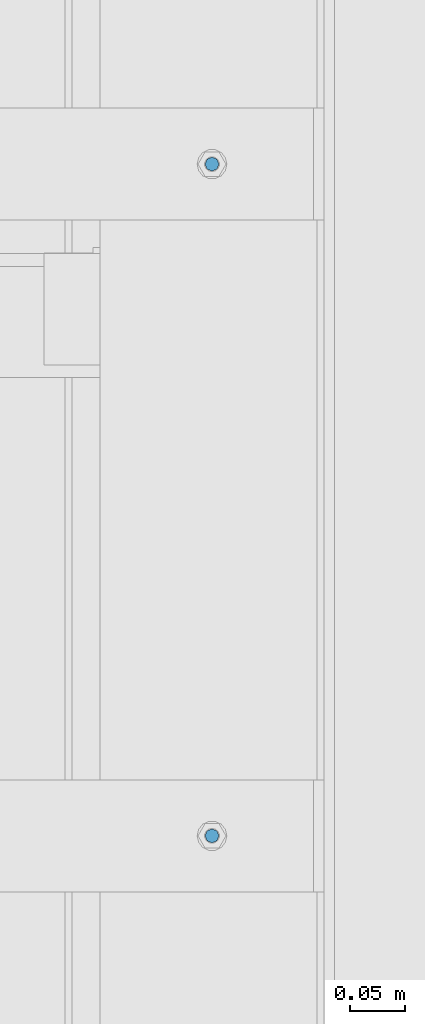
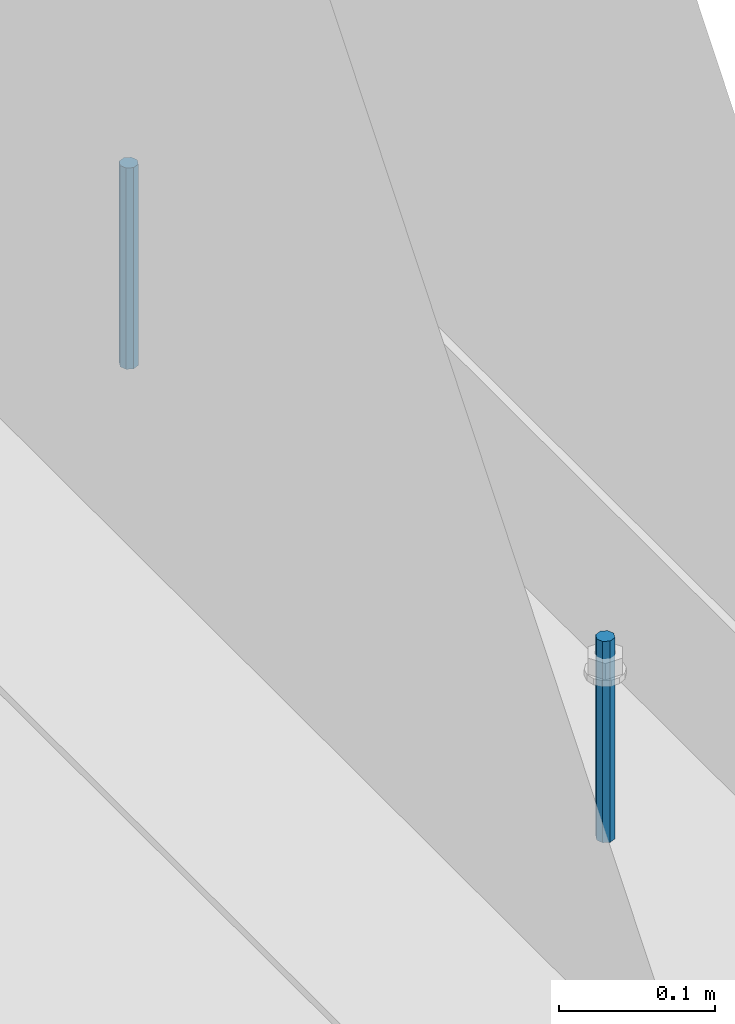
# One storey, part 447 of 1179: 2 columns, 1 element without a shape of its own.
"""IFC2X3 building model written with IfcOpenShell, lengths in millimetres."""

from ifc_helpers import new_model, si_unit, frame, origin_with_axes, place, context, subcontext, project, spatial, faceted_brep, material, type_object, element, aggregate, save


model = new_model("IFC2X3")

# Units and contexts
model_context = context("Model", 3, precision=1e-05, world=origin_with_axes())
body_context = subcontext(model_context, "Body", "Model", "MODEL_VIEW")
ifc_project = project(units=[si_unit("LENGTHUNIT", "METRE", prefix="MILLI"), si_unit("AREAUNIT", "SQUARE_METRE"), si_unit("VOLUMEUNIT", "CUBIC_METRE"), si_unit("MASSUNIT", "GRAM", prefix="KILO"), si_unit("TIMEUNIT", "SECOND"), si_unit("PLANEANGLEUNIT", "RADIAN"), si_unit("SOLIDANGLEUNIT", "STERADIAN"), si_unit("THERMODYNAMICTEMPERATUREUNIT", "DEGREE_CELSIUS"), si_unit("LUMINOUSINTENSITYUNIT", "LUMEN")], contexts=[model_context])

# Site, building, storey
site_placement = place(None, origin_with_axes())
site = spatial("IfcSite", under=ifc_project, at=site_placement, CompositionType="ELEMENT")
building_placement = place(site_placement, origin_with_axes())
building = spatial("IfcBuilding", under=site, at=building_placement, Name="Undefined", CompositionType="ELEMENT")
storey_placement = place(building_placement, origin_with_axes())
storey = spatial("IfcBuildingStorey", under=building, at=storey_placement, Name="Undefined", CompositionType="ELEMENT", Elevation=0.0)

# Assembly, columns
assembly_placement = place(storey_placement, origin_with_axes())
assembly = element("IfcElementAssembly", 1, at=assembly_placement, inside=storey, Name="BEAM", AssemblyPlace="NOTDEFINED", PredefinedType="RIGID_FRAME")
ifc_material = material(Name="STEEL/A307")
column_type = type_object("IfcColumnType", PredefinedType="NOTDEFINED")
column_1_placement = place(assembly_placement, frame((24638.0, 21310.6, 4108.45), z_axis=(0.0, 1.0, 0.0), x_axis=(0.0, 0.0, 1.0)))
column_1 = element("IfcColumn", 2, at=column_1_placement, type_object=column_type, material=ifc_material, Name="THREADED ROD", context=body_context, shape_type="Brep", body=[
    faceted_brep([(0.0, -6.34999999999854, 0.0), (0.0, -4.49012806053361, -4.49012806053452), (157.162499999999, -4.49012806053361, -4.49012806053361), (157.162499999999, -6.34999999999854, 0.0), (0.0, 0.0, -6.34999999999991), (157.162499999999, 0.0, -6.34999999999854), (0.0, 4.49012806053361, -4.49012806053452), (157.162499999999, 4.49012806053361, -4.49012806053361), (0.0, 6.34999999999854, 0.0), (157.162499999999, 6.34999999999854, 0.0), (0.0, 4.49012806053361, 4.49012806053452), (157.162499999999, 4.49012806053361, 4.49012806053361), (0.0, 0.0, 6.34999999999991), (157.162499999999, 0.0, 6.34999999999854), (0.0, -4.49012806053361, 4.49012806053452), (157.162499999999, -4.49012806053361, 4.49012806053361)], [[[0, 1, 2, 3]], [[1, 4, 5, 2]], [[4, 6, 7, 5]], [[6, 8, 9, 7]], [[8, 10, 11, 9]], [[10, 12, 13, 11]], [[12, 14, 15, 13]], [[14, 0, 3, 15]], [[5, 7, 9, 11, 13, 15, 3, 2]], [[14, 12, 10, 8, 6, 4, 1, 0]]]),
])
column_2_placement = place(assembly_placement, frame((24638.0, 20701.0, 4108.45), z_axis=(0.0, 1.0, 0.0), x_axis=(0.0, 0.0, 1.0)))
column_2 = element("IfcColumn", 3, at=column_2_placement, type_object=column_type, material=ifc_material, Name="THREADED ROD", context=body_context, shape_type="Brep", body=[
    faceted_brep([(0.0, -6.34999999999854, 0.0), (0.0, -4.49012806053361, -4.49012806053452), (157.162499999999, -4.49012806053361, -4.49012806053361), (157.162499999999, -6.34999999999854, 0.0), (0.0, 0.0, -6.34999999999991), (157.162499999999, 0.0, -6.34999999999854), (0.0, 4.49012806053361, -4.49012806053452), (157.162499999999, 4.49012806053361, -4.49012806053361), (0.0, 6.34999999999854, 0.0), (157.162499999999, 6.34999999999854, 0.0), (0.0, 4.49012806053361, 4.49012806053452), (157.162499999999, 4.49012806053361, 4.49012806053361), (0.0, 0.0, 6.34999999999991), (157.162499999999, 0.0, 6.34999999999854), (0.0, -4.49012806053361, 4.49012806053452), (157.162499999999, -4.49012806053361, 4.49012806053361)], [[[0, 1, 2, 3]], [[1, 4, 5, 2]], [[4, 6, 7, 5]], [[6, 8, 9, 7]], [[8, 10, 11, 9]], [[10, 12, 13, 11]], [[12, 14, 15, 13]], [[14, 0, 3, 15]], [[5, 7, 9, 11, 13, 15, 3, 2]], [[14, 12, 10, 8, 6, 4, 1, 0]]]),
])
aggregate(assembly, [column_1, column_2])

save(model, "model.ifc")
